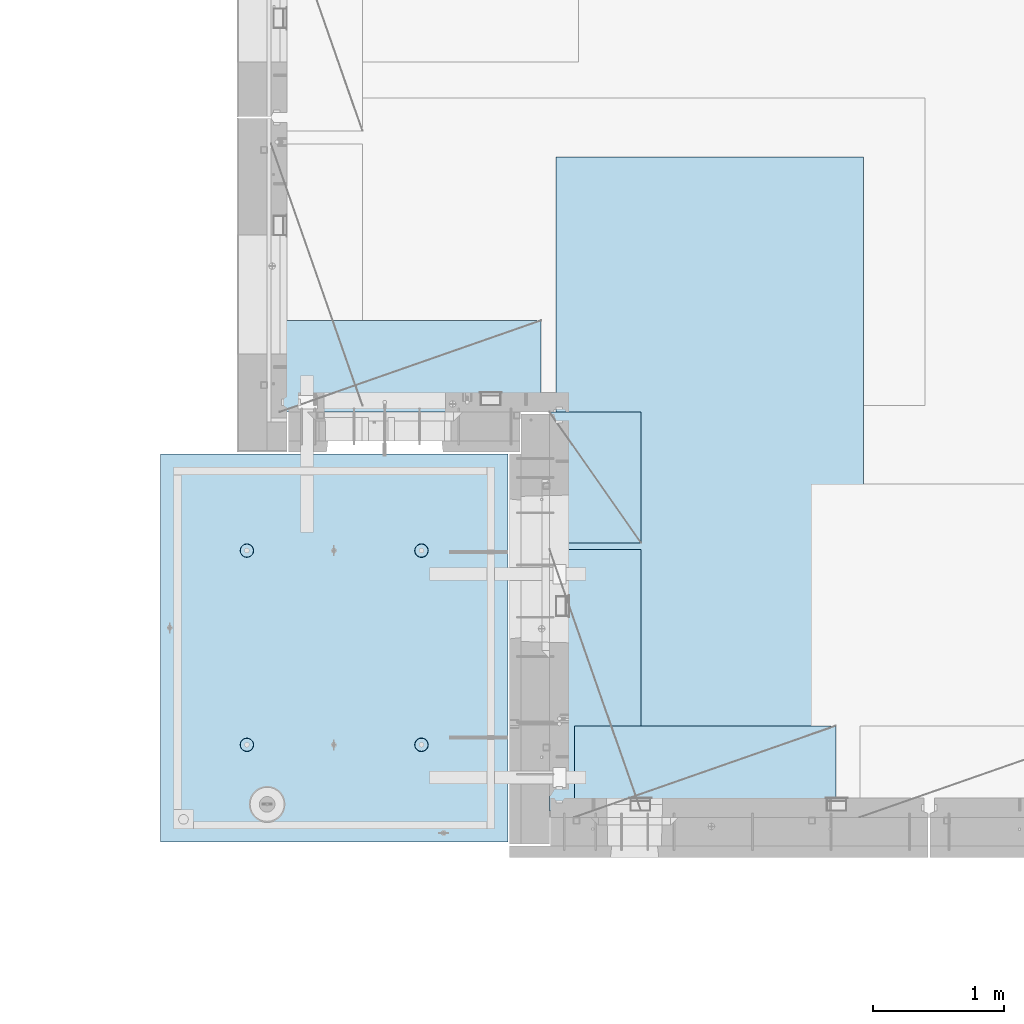
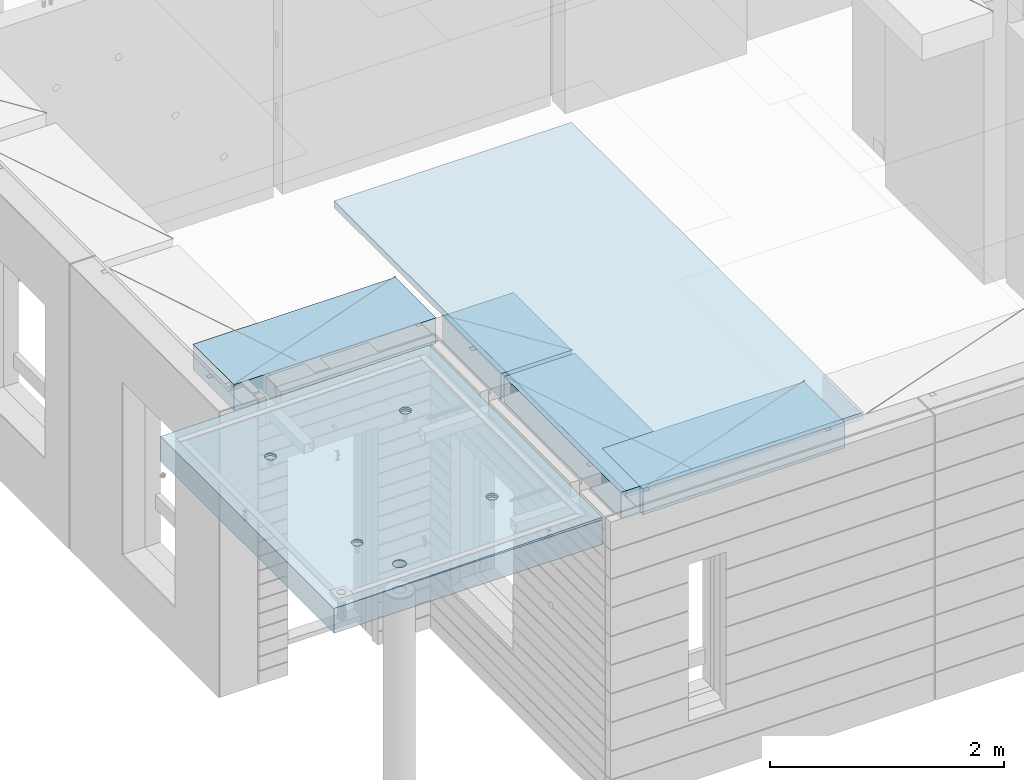
# One storey, part 198 of 352: 5 plates, 2 slabs, 6 elements without a shape of their own.
"""IFC2X3 building model written with IfcOpenShell, lengths in millimetres."""

from ifc_helpers import new_model, si_unit, frame, origin_with_axes, place, context, subcontext, project, spatial, faceted_brep, material, type_object, element, aggregate, save


model = new_model("IFC2X3")

# Units and contexts
model_context = context("Model", 3, precision=1e-05, world=origin_with_axes())
body_context = subcontext(model_context, "Body", "Model", "MODEL_VIEW")
ifc_project = project(units=[si_unit("LENGTHUNIT", "METRE", prefix="MILLI"), si_unit("AREAUNIT", "SQUARE_METRE"), si_unit("VOLUMEUNIT", "CUBIC_METRE"), si_unit("MASSUNIT", "GRAM", prefix="KILO"), si_unit("TIMEUNIT", "SECOND"), si_unit("PLANEANGLEUNIT", "RADIAN"), si_unit("SOLIDANGLEUNIT", "STERADIAN"), si_unit("THERMODYNAMICTEMPERATUREUNIT", "DEGREE_CELSIUS"), si_unit("LUMINOUSINTENSITYUNIT", "LUMEN")], contexts=[model_context])

# Site, building, storey
site_placement = place(None, origin_with_axes())
site = spatial("IfcSite", under=ifc_project, at=site_placement, CompositionType="ELEMENT")
building_placement = place(site_placement, origin_with_axes())
building = spatial("IfcBuilding", under=site, at=building_placement, CompositionType="ELEMENT")
storey_placement = place(building_placement, origin_with_axes())
storey = spatial("IfcBuildingStorey", under=building, at=storey_placement, Name="6", CompositionType="ELEMENT", Elevation=0.0)

# Assembly, slabs
assembly_1_placement = place(storey_placement, origin_with_axes())
assembly_1 = element("IfcElementAssembly", 1, at=assembly_1_placement, inside=storey, AssemblyPlace="NOTDEFINED", PredefinedType="REINFORCEMENT_UNIT")
ifc_material_1 = material(Name="CONCRETE/C35/45")
slab_type_1 = type_object("IfcSlabType", PredefinedType="NOTDEFINED")
slab_1_placement = place(assembly_1_placement, frame((9690.00344264774, 7659.99985681325, 99717.5), z_axis=(-1.0, 3.00000001838171e-08, 0.0), x_axis=(0.0, 1.0, 0.0)))
slab_1 = element("IfcSlab", 2, at=slab_1_placement, type_object=slab_type_1, material=ifc_material_1, PredefinedType="FLOOR", context=body_context, shape_type="Brep", body=[
    faceted_brep([(2970.0, 12.5, 2076.56396484375), (2970.0, 12.5, 2655.10375976563), (2970.0, 7.05330645262438, 2076.56396484375), (2970.0, 12.5, 0.0), (2969.99999999997, -12.5000027287315, -0.000215120240682154), (7.41420080885291e-08, 12.4999999999927, 0.0), (-7.41420080885291e-08, -12.5, -3.63797880709171e-12), (0.0, 12.5, 2655.00366210938), (2246.17288192116, -6.7539579669974, 610.235903379627), (2245.81872714612, 12.5, 611.325879700402), (2230.00000005311, 12.5, 608.820439463128), (2230.00000005311, -6.77809034052189, 607.672934085716), (2260.76019932669, -6.68392947182292, 617.673133503364), (2260.0890070157, 12.5, 618.596950465364), (2272.332530811, -6.57487936261168, 629.254531739907), (2271.41396524135, 12.5, 629.921908691014), (2279.75709784774, -6.43750647555862, 643.843854552742), (2278.68503600632, 12.5, 644.192188560603), (2282.30864751904, -6.2852774275234, 660.010915653605), (2281.19047624359, 12.5, 660.010915653605), (2279.73986529519, -6.13310092446045, 676.172377558725), (2278.68503600632, 12.5, 675.829642746608), (2272.30464795307, -5.995865551522, 690.747041485218), (2271.41396524135, 12.5, 690.099922616197), (2260.73231646608, -5.88698525390646, 702.310320338618), (2260.0890070157, 12.5, 701.424880841847), (2246.15564936427, -5.81709377811057, 709.732891570933), (2245.81872714612, 12.5, 708.695951606809), (2230.00000005311, -5.7930130083696, 712.290261666009), (2230.00000005311, 12.5, 711.201391844083), (2213.8443507625, -5.8170926610037, 709.732891507694), (2214.18127296011, 12.5, 708.695951606811), (2199.2676837145, -5.88698312871566, 702.310320236276), (2199.91099309052, 12.5, 701.424880841847), (2187.69535229405, -5.99586262571393, 690.747041382852), (2188.58603486487, 12.5, 690.099922616197), (2180.26013500581, -6.13309748387837, 676.172377495441), (2181.31496409991, 12.5, 675.829642746608), (2177.6913528026, -6.28527380865125, 660.010915653605), (2178.80952386264, 12.5, 660.010915653605), (2180.24290245339, -6.43750303260458, 643.843854616072), (2181.31496409991, 12.5, 644.192188560603), (2187.66746943631, -6.57487643294735, 629.254531842409), (2188.58603486487, 12.5, 629.921908691014), (2199.23980085403, -6.68392734277586, 617.673133605889), (2199.91099309052, 12.5, 618.596950465364), (2213.82711820565, -6.75395684751857, 610.235903443003), (2214.18127296011, 12.5, 611.325879700402), (761.172882674973, -6.75400078258826, 610.225900828256), (760.818727112381, 12.5, 611.315879572843), (745.000000019378, 12.5, 608.81043933557), (745.000000019378, -6.77813315729145, 607.662931409541), (775.760200790834, -6.68397228400863, 617.663131314152), (775.089006981969, 12.5, 618.586950337805), (787.33253283866, -6.57492216948594, 629.244530114656), (786.413965207619, 12.5, 629.911908563456), (794.757100236948, -6.437549275739, 643.833853637923), (793.685035972581, 12.5, 644.182188433044), (797.308650032492, -6.28532022031141, 660.000915526047), (796.190476209855, 12.5, 660.000915526047), (794.739867683551, -6.13314370981243, 676.162378218156), (793.685035972581, 12.5, 675.81964261905), (787.304649979378, -5.9959083302092, 690.737042854367), (786.413965207619, 12.5, 690.089922488638), (775.732317928869, -5.88702802728221, 702.300322270843), (775.089006981969, 12.5, 701.414880714288), (761.155650117242, -5.81713654809573, 709.722893864604), (760.818727112381, 12.5, 708.68595147925), (745.000000019378, -5.79305577717605, 712.280264084213), (745.000000019378, 12.5, 711.191391716524), (728.844349942063, -5.8171354309743, 709.722893801363), (729.181272926375, 12.5, 708.68595147925), (714.267682184241, -5.88702590207686, 702.300322168503), (714.910993056787, 12.5, 701.414880714288), (702.695350200273, -5.99590540440113, 690.737042752), (703.586034831136, 12.5, 690.089922488638), (695.260132549976, -6.1331402692449, 676.16237815487), (696.314964066174, 12.5, 675.81964261905), (692.691350221674, -6.28531660142471, 660.000915526047), (693.809523828902, 12.5, 660.000915526047), (695.242899996714, -6.43754583279951, 643.833853701251), (696.314964066174, 12.5, 644.182188433044), (702.667467341174, -6.57491923982161, 629.244530217156), (703.586034831136, 12.5, 629.911908563456), (714.239799322411, -6.68397015496157, 617.663131416677), (714.910993056787, 12.5, 618.586950337805), (728.827117384375, -6.75399966310943, 610.225900891632), (729.181272926375, 12.5, 611.315879572843), (760.941541335169, 5.82308796475991, 1945.93972725137), (760.818727091786, 12.5, 1946.31771062636), (744.999999998783, 12.5, 1943.81227038909), (744.999999998783, 5.79930078610778, 1943.4134192454), (775.320198478928, 5.89211475661432, 1953.2705735664), (775.089006961374, 12.5, 1953.58878139132), (786.72699673669, 5.99960498859582, 1964.68630888353), (786.413965187025, 12.5, 1964.91373961697), (794.045361100365, 6.13501286304381, 1979.06694274881), (793.685035951987, 12.5, 1979.18401948656), (796.560412832556, 6.28506439260673, 1995.00274657956), (796.190476189258, 12.5, 1995.00274657956), (794.028375046106, 6.43506412883289, 2010.93303130673), (793.685035951987, 12.5, 2010.82147367257), (786.699512721421, 6.57033645619231, 2025.29921596966), (786.413965187025, 12.5, 2025.09175354215), (775.292714461017, 6.67765930559835, 2036.69709108738), (775.089006961374, 12.5, 2036.41671176781), (760.924555276639, 6.74655103802797, 2044.01348819506), (760.818727091786, 12.5, 2043.68778253277), (744.999999998783, 6.7702873510425, 2046.53427709438), (744.999999998783, 12.5, 2046.19322277004), (729.075444741182, 6.7465521391714, 2044.01348813272), (729.18127290578, 12.5, 2043.68778253277), (714.70728560984, 6.67766140039021, 2036.6970909865), (714.910993036192, 12.5, 2036.41671176781), (703.300487415023, 6.57033934014908, 2025.29921586876), (703.586034810542, 12.5, 2025.09175354216), (695.971625143447, 6.43506752018584, 2010.93303124435), (696.314964045579, 12.5, 2010.82147367257), (693.439587377337, 6.28506795971771, 1995.00274657956), (693.809523808306, 12.5, 1995.00274657956), (695.954639089321, 6.13501625673962, 1979.06694281123), (696.314964045579, 12.5, 1979.18401948656), (703.273003399938, 5.99960787635064, 1964.68630898457), (703.586034810542, 12.5, 1964.91373961697), (714.679801592063, 5.89211685521877, 1953.27057366746), (714.910993036192, 12.5, 1953.58878139132), (729.058458682694, 5.82308906823164, 1945.93972731384), (729.18127290578, 12.5, 1946.31771062636), (2178.80952377932, 12.5, 1995.00274667064), (2178.43958429075, 6.28501659208268, 1995.00274667064), (2180.95463615188, 6.13496488021337, 1979.06694195729), (2181.31496401659, 12.5, 1979.18401957764), (2181.31496401659, 12.5, 2010.82147376364), (2180.97162220701, 6.43501616145659, 2010.93303228012), (2188.58603478155, 12.5, 2025.09175363323), (2188.3004849132, 6.57028798943793, 2025.29921775646), (2199.9109930072, 12.5, 2036.41671185888), (2199.70728378446, 6.6776100560528, 2036.6970935501), (2214.18127287679, 12.5, 2043.68778262385), (2214.07544376785, 6.74650079890853, 2044.0134911302), (2229.9999999698, 12.5, 2046.19322286112), (2229.9999999698, 6.77023601217661, 2046.53428024135), (2245.8187270628, 12.5, 2043.68778262385), (2245.924556192, 6.7464996977651, 2044.01349119253), (2260.08900693239, 12.5, 2036.41671185888), (2260.29271622843, 6.67760796126095, 2036.69709365098), (2271.41396515804, 12.5, 2025.09175363323), (2271.69951516527, 6.57028510548116, 2025.29921785736), (2278.685035923, 12.5, 2010.82147376364), (2279.02837792456, 6.43501277010364, 2010.9330323425), (2281.19047616027, 12.5, 1995.00274667064), (2281.56041586117, 6.2850130249717, 1995.00274667064), (2278.685035923, 12.5, 1979.18401957764), (2279.04536397983, 6.13496148651757, 1979.06694189487), (2271.41396515804, 12.5, 1964.91373970805), (2271.72699918216, 5.99955360403692, 1964.68630717681), (2260.08900693239, 12.5, 1953.5887814824), (2260.32020024797, 5.89206336568168, 1953.2705711827), (2245.8187270628, 12.5, 1946.31771071744), (2245.94154225154, 5.82303656973818, 1945.93972443295), (254.731823253564, 4.36849820162752, 1791.45731182264), (241.457918728614, 4.49348581883532, 1804.73121634759), (232.935547413403, 4.65097912067722, 1821.45731182264), (229.998938391112, 4.82556156541978, 1839.99833148514), (232.935547413403, 5.00014380698849, 1858.53935114764), (241.457918728614, 5.15763651921588, 1875.26544662269), (254.731823253564, 5.28262321809598, 1888.53935114764), (271.457918728614, 5.36286933471274, 1897.06172246285), (289.998938391112, 5.3905198200664, 1899.99833148514), (308.539958053609, 5.36286805199052, 1897.06172246285), (325.26605352866, 5.28262077822001, 1888.53935114764), (338.539958053609, 5.15763316099765, 1875.26544662269), (347.06232936882, 5.0001398591703, 1858.53935114764), (349.998938391112, 4.82555741442775, 1839.99833148514), (347.06232936882, 4.65097517284448, 1821.45731182264), (338.539958053609, 4.49348246061709, 1804.73121634759), (325.26605352866, 4.36849576173699, 1791.45731182264), (308.539958053609, 4.28824964510568, 1782.93494050743), (289.998938391112, 4.26059915976657, 1779.99833148514), (271.457918728614, 4.28825092784246, 1782.93494050743), (2199.67979976505, 5.89206546428613, 1953.27057128376), (2188.27300089649, 5.99955649179174, 1964.68630727784), (2229.9999999698, 5.79924938967451, 1943.41341627717), (2214.05845770835, 5.82303767320991, 1945.93972449542), (2188.58603478155, 12.5, 1964.91373970805), (2199.9109930072, 12.5, 1953.5887814824), (2214.18127287679, 12.5, 1946.31771071744), (2229.9999999698, 12.5, 1943.81227048017), (325.26605352866, 12.5, 1791.45731182264), (338.539958053609, 12.5, 1804.73121634759), (347.06232936882, 12.5, 1821.45731182264), (349.998938391112, 12.5, 1839.99833148514), (347.06232936882, 12.5, 1858.53935114764), (338.539958053609, 12.5, 1875.26544662269), (325.26605352866, 12.5, 1888.53935114764), (308.539958053609, 12.5, 1897.06172246285), (289.998938391112, 12.5, 1899.99833148514), (271.457918728614, 12.5, 1897.06172246285), (254.731823253564, 12.5, 1888.53935114764), (241.457918728614, 12.5, 1875.26544662269), (232.935547413403, 12.5, 1858.53935114764), (229.998938391112, 12.5, 1839.99833148514), (232.935547413403, 12.5, 1821.45731182264), (241.457918728614, 12.5, 1804.73121634759), (254.731823253564, 12.5, 1791.45731182264), (271.457918728614, 12.5, 1782.93494050743), (289.998938391112, 12.5, 1779.99833148514), (308.539958053609, 12.5, 1782.93494050743)], [[[0, 1, 2]], [[3, 0, 2, 4]], [[5, 3, 4, 6]], [[5, 6, 7]], [[8, 9, 10, 11]], [[12, 13, 9, 8]], [[14, 15, 13, 12]], [[16, 17, 15, 14]], [[18, 19, 17, 16]], [[20, 21, 19, 18]], [[21, 20, 22, 23]], [[23, 22, 24, 25]], [[25, 24, 26, 27]], [[27, 26, 28, 29]], [[29, 28, 30, 31]], [[31, 30, 32, 33]], [[33, 32, 34, 35]], [[35, 34, 36, 37]], [[37, 36, 38, 39]], [[40, 41, 39, 38]], [[42, 43, 41, 40]], [[44, 45, 43, 42]], [[46, 47, 45, 44]], [[11, 10, 47, 46]], [[48, 49, 50, 51]], [[52, 53, 49, 48]], [[54, 55, 53, 52]], [[56, 57, 55, 54]], [[58, 59, 57, 56]], [[60, 61, 59, 58]], [[61, 60, 62, 63]], [[63, 62, 64, 65]], [[65, 64, 66, 67]], [[67, 66, 68, 69]], [[69, 68, 70, 71]], [[71, 70, 72, 73]], [[73, 72, 74, 75]], [[75, 74, 76, 77]], [[77, 76, 78, 79]], [[80, 81, 79, 78]], [[82, 83, 81, 80]], [[84, 85, 83, 82]], [[86, 87, 85, 84]], [[51, 50, 87, 86]], [[88, 89, 90, 91]], [[92, 93, 89, 88]], [[94, 95, 93, 92]], [[96, 97, 95, 94]], [[98, 99, 97, 96]], [[100, 101, 99, 98]], [[102, 103, 101, 100]], [[104, 105, 103, 102]], [[105, 104, 106, 107]], [[107, 106, 108, 109]], [[109, 108, 110, 111]], [[111, 110, 112, 113]], [[113, 112, 114, 115]], [[115, 114, 116, 117]], [[117, 116, 118, 119]], [[119, 118, 120, 121]], [[121, 120, 122, 123]], [[124, 125, 123, 122]], [[126, 127, 125, 124]], [[91, 90, 127, 126]], [[128, 129, 130, 131]], [[132, 133, 129, 128]], [[134, 135, 133, 132]], [[136, 137, 135, 134]], [[138, 139, 137, 136]], [[140, 141, 139, 138]], [[142, 143, 141, 140]], [[144, 145, 143, 142]], [[145, 144, 146, 147]], [[147, 146, 148, 149]], [[149, 148, 150, 151]], [[151, 150, 152, 153]], [[153, 152, 154, 155]], [[155, 154, 156, 157]], [[157, 156, 158, 159]], [[4, 2, 1, 7, 6], [160, 161, 162, 163, 164, 165, 166, 167, 168, 169, 170, 171, 172, 173, 174, 175, 176, 177, 178, 179], [180, 181, 130, 129, 133, 135, 137, 139, 141, 143, 145, 147, 149, 151, 153, 155, 157, 159, 182, 183], [124, 122, 120, 118, 116, 114, 112, 110, 108, 106, 104, 102, 100, 98, 96, 94, 92, 88, 91, 126], [84, 82, 80, 78, 76, 74, 72, 70, 68, 66, 64, 62, 60, 58, 56, 54, 52, 48, 51, 86], [44, 42, 40, 38, 36, 34, 32, 30, 28, 26, 24, 22, 20, 18, 16, 14, 12, 8, 11, 46]], [[131, 130, 181, 184]], [[180, 185, 184, 181]], [[183, 186, 185, 180]], [[182, 187, 186, 183]], [[159, 158, 187, 182]], [[0, 3, 5, 7, 1], [188, 189, 190, 191, 192, 193, 194, 195, 196, 197, 198, 199, 200, 201, 202, 203, 204, 205, 206, 207], [156, 154, 152, 150, 148, 146, 144, 142, 140, 138, 136, 134, 132, 128, 131, 184, 185, 186, 187, 158], [93, 95, 97, 99, 101, 103, 105, 107, 109, 111, 113, 115, 117, 119, 121, 123, 125, 127, 90, 89], [53, 55, 57, 59, 61, 63, 65, 67, 69, 71, 73, 75, 77, 79, 81, 83, 85, 87, 50, 49], [13, 15, 17, 19, 21, 23, 25, 27, 29, 31, 33, 35, 37, 39, 41, 43, 45, 47, 10, 9]], [[178, 206, 205, 179]], [[177, 207, 206, 178]], [[176, 188, 207, 177]], [[175, 189, 188, 176]], [[174, 190, 189, 175]], [[173, 191, 190, 174]], [[172, 192, 191, 173]], [[171, 193, 192, 172]], [[170, 194, 193, 171]], [[169, 195, 194, 170]], [[168, 196, 195, 169]], [[167, 197, 196, 168]], [[166, 198, 197, 167]], [[165, 199, 198, 166]], [[164, 200, 199, 165]], [[163, 201, 200, 164]], [[162, 202, 201, 163]], [[161, 203, 202, 162]], [[160, 204, 203, 161]], [[179, 205, 204, 160]]]),
])
slab_type_2 = type_object("IfcSlabType", PredefinedType="NOTDEFINED")
slab_2_placement = place(assembly_1_placement, frame((9690.00344264774, 7659.99985681325, 99575.0), z_axis=(-0.999999999997437, -2.26400000064461e-06, 0.0), x_axis=(-2.2639999995273e-06, 0.999999999997437, 0.0)))
slab_2 = element("IfcSlab", 3, at=slab_2_placement, type_object=slab_type_2, material=ifc_material_1, PredefinedType="FLOOR", context=body_context, shape_type="Brep", body=[
    faceted_brep([(2245.45536387143, -110.0, 1947.44471589559), (2259.39379322965, -110.0, 1954.54665968234), (2270.4554059745, -110.0, 1965.60822114567), (2277.55741437973, -110.0, 1979.54661757913), (2280.00462438004, -110.0, 1994.99746162528), (2277.55748600988, -110.0, 2010.44831701654), (2270.45554222312, -110.0, 2024.38674637476), (2259.39398075979, -110.0, 2035.44835911961), (2245.45558432633, -110.0, 2042.55036752485), (2230.00474028018, -110.0, 2044.99757752515), (2214.55388488892, -110.0, 2042.55043915498), (2200.6154555307, -110.0, 2035.44849536823), (2189.55384278585, -110.0, 2024.3869339049), (2182.45183438062, -110.0, 2010.44853747144), (2180.00462438031, -110.0, 1994.99769342529), (2182.45176275048, -110.0, 1979.54683803403), (2189.55370653723, -110.0, 1965.60840867581), (2200.61526800056, -110.0, 1954.54679593096), (2214.55366443402, -110.0, 1947.44478752572), (2230.00450848018, -110.0, 1944.99757752542), (2260.09353534512, -130.0, 1953.58354259084), (2245.82323862122, -130.0, 1946.3125049044), (2271.41851982199, -130.0, 1964.9084745652), (2278.68962366544, -130.0, 1979.17873758041), (2281.19510057052, -130.0, 1994.99745886576), (2278.68969700106, -130.0, 2010.81619176633), (2271.41865931462, -130.0, 2025.08648849022), (2260.09372734026, -130.0, 2036.4114729671), (2245.82346432505, -130.0, 2043.68257681055), (2230.0047430397, -130.0, 2046.18805371562), (2214.18601013913, -130.0, 2043.68265014617), (2199.91571341524, -130.0, 2036.41161245973), (2188.59072893836, -130.0, 2025.08668048537), (2181.31962509491, -130.0, 2010.81641747016), (2178.81414818984, -130.0, 1994.99769618481), (2181.31955175929, -130.0, 1979.17896328424), (2188.59058944573, -130.0, 1964.90866656035), (2199.91552142009, -130.0, 1953.58368208347), (2214.1857844353, -130.0, 1946.31257824002), (2230.00450572065, -130.0, 1943.80710133495), (760.455363904408, -110.0, 1947.44815803451), (774.393793262629, -110.0, 1954.55010182126), (785.455406007481, -110.0, 1965.61166328459), (792.557414412711, -110.0, 1979.55005971805), (795.004624413019, -110.0, 1995.00090376421), (792.557486042851, -110.0, 2010.45175915546), (785.455542256102, -110.0, 2024.39018851368), (774.393980792767, -110.0, 2035.45180125853), (760.455584359308, -110.0, 2042.55380966377), (745.004740313152, -110.0, 2045.00101966407), (729.553884921896, -110.0, 2042.55388129391), (715.615455563677, -110.0, 2035.45193750716), (704.553842818825, -110.0, 2024.39037604382), (697.451834413594, -110.0, 2010.45197961036), (695.004624413286, -110.0, 1995.00113556421), (697.451762783454, -110.0, 1979.55028017295), (704.553706570203, -110.0, 1965.61185081473), (715.615268033538, -110.0, 1954.55023806988), (729.553664466996, -110.0, 1947.44822966465), (745.004508513151, -110.0, 1945.00101966434), (760.823238654199, -130.0, 1946.31594704332), (745.004505753628, -130.0, 1943.81054347387), (775.093535378091, -130.0, 1953.58698472976), (786.418519854964, -130.0, 1964.91191670413), (793.689623698416, -130.0, 1979.18217971933), (796.195100603492, -130.0, 1995.00090100468), (793.689697034035, -130.0, 2010.81963390525), (786.418659347601, -130.0, 2025.08993062915), (775.093727373234, -130.0, 2036.41491510602), (760.823464358025, -130.0, 2043.68601894947), (745.004743072675, -130.0, 2046.19149585455), (729.186010172105, -130.0, 2043.68609228509), (714.915713448214, -130.0, 2036.41505459866), (703.590728971341, -130.0, 2025.09012262429), (696.319625127888, -130.0, 2010.81985960908), (693.814148222813, -130.0, 1995.00113832373), (696.319551792269, -130.0, 1979.18240542316), (703.590589478705, -130.0, 1964.91210869927), (714.915521453071, -130.0, 1953.5871242224), (729.185784468278, -130.0, 1946.31602037894), (2970.0, -130.0, 1.11504050437361e-09), (0.0, -130.0, -3.63797880709171e-12), (0.0, 130.0, -1.81898940354586e-12), (2970.0, 130.0, 1.11504050437361e-09), (2970.0048828125, -130.0, 2076.55712890625), (2970.0048828125, 130.0, 2076.55712890625), (2970.00610351563, -130.0, 2655.0966796875), (2970.00610351563, 130.0, 2655.0966796875), (0.00277573079893045, -130.0, 2655.00366210937), (0.00277573079893045, 130.0, 2655.00366210937), (325.270206125839, 130.0, 1791.45655785112), (338.544141419662, 130.0, 1804.73043160713), (347.066551505941, 130.0, 1821.45650732727), (350.003203506308, 130.0, 1839.99752018266), (347.066637462108, 130.0, 1858.53854665217), (338.544304918008, 130.0, 1875.26466188203), (325.270431162006, 130.0, 1888.53859717586), (308.544355441856, 130.0, 1897.06100726213), (290.003342586469, 130.0, 1899.9976592625), (271.462316116962, 130.0, 1897.0610932183), (254.7362008871, 130.0, 1888.5387606742), (241.462265593274, 130.0, 1875.2648869182), (232.939855506997, 130.0, 1858.53881119805), (230.00320350663, 130.0, 1839.99779834266), (232.93976955083, 130.0, 1821.45677187316), (241.462102094929, 130.0, 1804.73065664329), (254.735975850932, 130.0, 1791.45672134947), (271.462051571081, 130.0, 1782.93431126319), (290.003064426469, 130.0, 1779.99765926282), (308.544090895975, 130.0, 1782.93422530702), (308.544090895975, -130.0, 1782.93422530702), (290.003064426469, -130.0, 1779.99765926282), (325.270206125839, -130.0, 1791.45655785112), (338.544141419662, -130.0, 1804.73043160713), (347.066551505941, -130.0, 1821.45650732727), (350.003203506308, -130.0, 1839.99752018266), (347.066637462108, -130.0, 1858.53854665217), (338.544304918008, -130.0, 1875.26466188203), (325.270431162006, -130.0, 1888.53859717586), (308.544355441856, -130.0, 1897.06100726213), (290.003342586469, -130.0, 1899.9976592625), (271.462316116962, -130.0, 1897.0610932183), (254.7362008871, -130.0, 1888.5387606742), (241.462265593274, -130.0, 1875.2648869182), (232.939855506997, -130.0, 1858.53881119805), (230.00320350663, -130.0, 1839.99779834266), (232.93976955083, -130.0, 1821.45677187316), (241.462102094929, -130.0, 1804.73065664329), (254.735975850932, -130.0, 1791.45672134947), (271.462051571081, -130.0, 1782.93431126319), (760.452269390758, -110.0, 612.446326984578), (774.390698748979, -110.0, 619.548270771327), (785.452311493831, -110.0, 630.609832234661), (792.554319899062, -110.0, 644.54822866812), (795.001529899369, -110.0, 659.999072714278), (792.554391529202, -110.0, 675.449928105532), (785.452447742453, -110.0, 689.388357463751), (774.390886279118, -110.0, 700.449970208605), (760.452489845658, -110.0, 707.551978613836), (745.001645799503, -110.0, 709.999188614142), (729.550790408246, -110.0, 707.552050243974), (715.612361050027, -110.0, 700.450106457225), (704.550748305175, -110.0, 689.388544993892), (697.448739899944, -110.0, 675.450148560432), (695.001529899637, -110.0, 659.999304514276), (697.448668269804, -110.0, 644.54844912302), (704.550612056553, -110.0, 630.610019764801), (715.612173519889, -110.0, 619.548407019947), (729.550569953346, -110.0, 612.446398614717), (745.001413999502, -110.0, 609.999188614411), (760.820144140549, -130.0, 611.314115993395), (745.001411239979, -130.0, 608.808712423936), (775.090440864442, -130.0, 618.585153679829), (786.415425341314, -130.0, 629.910085654195), (793.686529184766, -130.0, 644.180348669403), (796.192006089843, -130.0, 659.999069954752), (793.686602520385, -130.0, 675.817802855323), (786.415564833951, -130.0, 690.088099579216), (775.090632859585, -130.0, 701.41308405609), (760.820369844376, -130.0, 708.68418789954), (745.001648559026, -130.0, 711.189664804615), (729.182915658455, -130.0, 708.684261235159), (714.912618934564, -130.0, 701.413223548725), (703.587634457692, -130.0, 690.088291574357), (696.316530614238, -130.0, 675.81802855915), (693.811053709163, -130.0, 659.999307273802), (696.316457278619, -130.0, 644.180574373229), (703.587494965055, -130.0, 629.910277649336), (714.912426939421, -130.0, 618.585293172464), (729.182689954629, -130.0, 611.314189329014), (2245.45226944368, -110.0, 612.452884882137), (2259.3906988019, -110.0, 619.554828668886), (2270.45231154675, -110.0, 630.61639013222), (2277.55431995199, -110.0, 644.554786565679), (2280.00152995229, -110.0, 660.005630611837), (2277.55439158212, -110.0, 675.456486003091), (2270.45244779537, -110.0, 689.39491536131), (2259.39088633204, -110.0, 700.456528106164), (2245.45248989858, -110.0, 707.558536511395), (2230.00164585242, -110.0, 710.005746511701), (2214.55079046117, -110.0, 707.558608141533), (2200.61236110295, -110.0, 700.456664354784), (2189.5507483581, -110.0, 689.395102891451), (2182.44873995286, -110.0, 675.456706457991), (2180.00152995256, -110.0, 660.005862411836), (2182.44866832273, -110.0, 644.555007020579), (2189.55061210948, -110.0, 630.61657766236), (2200.61217357281, -110.0, 619.554964917506), (2214.55057000627, -110.0, 612.452956512276), (2230.00141405243, -110.0, 610.00574651197), (2245.82014419347, -130.0, 611.320673890954), (2230.0014112929, -130.0, 608.815270321495), (2260.09044091736, -130.0, 618.591711577388), (2271.41542539424, -130.0, 629.916643551753), (2278.68652923769, -130.0, 644.186906566962), (2281.19200614276, -130.0, 660.005627852312), (2278.68660257331, -130.0, 675.824360752882), (2271.41556488687, -130.0, 690.094657476773), (2260.09063291251, -130.0, 701.419641953647), (2245.8203698973, -130.0, 708.690745797099), (2230.00164861195, -130.0, 711.196222702174), (2214.18291571138, -130.0, 708.690819132718), (2199.91261898749, -130.0, 701.419781446282), (2188.58763451061, -130.0, 690.094849471916), (2181.31653066716, -130.0, 675.824586456709), (2178.81105376209, -130.0, 660.005865171361), (2181.31645733154, -130.0, 644.187132270788), (2188.58749501798, -130.0, 629.916835546896), (2199.91242699234, -130.0, 618.591851070023), (2214.18269000755, -130.0, 611.320747226573)], [[[0, 1, 2, 3, 4, 5, 6, 7, 8, 9, 10, 11, 12, 13, 14, 15, 16, 17, 18, 19]], [[20, 1, 0, 21]], [[22, 2, 1, 20]], [[23, 3, 2, 22]], [[24, 4, 3, 23]], [[25, 5, 4, 24]], [[26, 6, 5, 25]], [[27, 7, 6, 26]], [[28, 8, 7, 27]], [[29, 9, 8, 28]], [[30, 10, 9, 29]], [[31, 11, 10, 30]], [[32, 12, 11, 31]], [[33, 13, 12, 32]], [[34, 14, 13, 33]], [[35, 15, 14, 34]], [[36, 16, 15, 35]], [[37, 17, 16, 36]], [[38, 18, 17, 37]], [[39, 19, 18, 38]], [[21, 0, 19, 39]], [[40, 41, 42, 43, 44, 45, 46, 47, 48, 49, 50, 51, 52, 53, 54, 55, 56, 57, 58, 59]], [[60, 40, 59, 61]], [[62, 41, 40, 60]], [[63, 42, 41, 62]], [[64, 43, 42, 63]], [[65, 44, 43, 64]], [[66, 45, 44, 65]], [[67, 46, 45, 66]], [[68, 47, 46, 67]], [[69, 48, 47, 68]], [[70, 49, 48, 69]], [[71, 50, 49, 70]], [[72, 51, 50, 71]], [[73, 52, 51, 72]], [[74, 53, 52, 73]], [[75, 54, 53, 74]], [[76, 55, 54, 75]], [[77, 56, 55, 76]], [[78, 57, 56, 77]], [[79, 58, 57, 78]], [[61, 59, 58, 79]], [[80, 81, 82, 83]], [[84, 80, 83, 85]], [[86, 84, 85, 87]], [[88, 86, 87, 89]], [[81, 88, 89, 82]], [[87, 85, 83, 82, 89], [90, 91, 92, 93, 94, 95, 96, 97, 98, 99, 100, 101, 102, 103, 104, 105, 106, 107, 108, 109]], [[110, 109, 108, 111]], [[112, 90, 109, 110]], [[113, 91, 90, 112]], [[114, 92, 91, 113]], [[115, 93, 92, 114]], [[116, 94, 93, 115]], [[117, 95, 94, 116]], [[118, 96, 95, 117]], [[119, 97, 96, 118]], [[120, 98, 97, 119]], [[121, 99, 98, 120]], [[122, 100, 99, 121]], [[123, 101, 100, 122]], [[124, 102, 101, 123]], [[125, 103, 102, 124]], [[126, 104, 103, 125]], [[127, 105, 104, 126]], [[128, 106, 105, 127]], [[129, 107, 106, 128]], [[111, 108, 107, 129]], [[130, 131, 132, 133, 134, 135, 136, 137, 138, 139, 140, 141, 142, 143, 144, 145, 146, 147, 148, 149]], [[150, 130, 149, 151]], [[152, 131, 130, 150]], [[153, 132, 131, 152]], [[154, 133, 132, 153]], [[155, 134, 133, 154]], [[156, 135, 134, 155]], [[157, 136, 135, 156]], [[158, 137, 136, 157]], [[159, 138, 137, 158]], [[160, 139, 138, 159]], [[161, 140, 139, 160]], [[162, 141, 140, 161]], [[163, 142, 141, 162]], [[164, 143, 142, 163]], [[165, 144, 143, 164]], [[166, 145, 144, 165]], [[167, 146, 145, 166]], [[168, 147, 146, 167]], [[169, 148, 147, 168]], [[151, 149, 148, 169]], [[170, 171, 172, 173, 174, 175, 176, 177, 178, 179, 180, 181, 182, 183, 184, 185, 186, 187, 188, 189]], [[190, 170, 189, 191]], [[192, 171, 170, 190]], [[193, 172, 171, 192]], [[194, 173, 172, 193]], [[195, 174, 173, 194]], [[196, 175, 174, 195]], [[197, 176, 175, 196]], [[198, 177, 176, 197]], [[199, 178, 177, 198]], [[200, 179, 178, 199]], [[201, 180, 179, 200]], [[202, 181, 180, 201]], [[203, 182, 181, 202]], [[204, 183, 182, 203]], [[205, 184, 183, 204]], [[206, 185, 184, 205]], [[207, 186, 185, 206]], [[208, 187, 186, 207]], [[209, 188, 187, 208]], [[191, 189, 188, 209]], [[80, 84, 86, 88, 81], [37, 36, 35, 34, 33, 32, 31, 30, 29, 28, 27, 26, 25, 24, 23, 22, 20, 21, 39, 38], [208, 207, 206, 205, 204, 203, 202, 201, 200, 199, 198, 197, 196, 195, 194, 193, 192, 190, 191, 209], [168, 167, 166, 165, 164, 163, 162, 161, 160, 159, 158, 157, 156, 155, 154, 153, 152, 150, 151, 169], [128, 127, 126, 125, 124, 123, 122, 121, 120, 119, 118, 117, 116, 115, 114, 113, 112, 110, 111, 129], [78, 77, 76, 75, 74, 73, 72, 71, 70, 69, 68, 67, 66, 65, 64, 63, 62, 60, 61, 79]]]),
])
aggregate(assembly_1, [slab_1, slab_2])

# Assembly, plate
assembly_2_placement = place(storey_placement, origin_with_axes())
assembly_2 = element("IfcElementAssembly", 4, at=assembly_2_placement, inside=storey, Name="Steel Assembly", AssemblyPlace="NOTDEFINED", PredefinedType="NOTDEFINED")
ifc_material_2 = material()
plate_type_1 = type_object("IfcPlateType", PredefinedType="NOTDEFINED")
plate_1_placement = place(assembly_2_placement, frame((10060.0, 7900.0, 99695.1), z_axis=(0.0, 1.0, 0.0), x_axis=(1.0, 0.0, 0.0)))
plate_1 = element("IfcPlate", 5, at=plate_1_placement, type_object=plate_type_1, material=ifc_material_2, context=body_context, shape_type="Brep", body=[
    faceted_brep([(0.0, -35.0, 0.0), (0.0, -35.0, 5000.0), (0.0, 35.0, 5000.0), (0.0, 35.0, 0.0), (2349.99951171875, -35.0, 5000.0), (2349.99951171875, 35.0, 5000.0), (2350.0, -35.0, 0.0), (2350.0, 35.0, 0.0)], [[[0, 1, 2, 3]], [[1, 4, 5, 2]], [[4, 6, 7, 5]], [[6, 0, 3, 7]], [[5, 7, 3, 2]], [[6, 4, 1, 0]]]),
])
aggregate(assembly_2, [plate_1])

assembly_3_placement = place(storey_placement, origin_with_axes())
assembly_3 = element("IfcElementAssembly", 6, at=assembly_3_placement, inside=storey, Name="Steel Assembly", AssemblyPlace="NOTDEFINED", PredefinedType="NOTDEFINED")
plate_type_2 = type_object("IfcPlateType", PredefinedType="NOTDEFINED")
plate_2_placement = place(assembly_3_placement, frame((7945.00085423865, 10950.0001036336, 99595.3), z_axis=(0.0, 1.0, 0.0), x_axis=(1.0, 0.0, 0.0)))
plate_2 = element("IfcPlate", 7, at=plate_2_placement, type_object=plate_type_2, material=ifc_material_2, Name="RE1", context=body_context, shape_type="Brep", body=[
    faceted_brep([(1.81898940354586e-12, -135.0, 1.81898940354586e-12), (0.0, -135.0, 699.999999999996), (0.0, 135.0, 699.999999999996), (1.81898940354586e-12, 135.0, 1.81898940354586e-12), (1999.99951171875, -135.0, 699.999999999993), (1999.99951171875, 135.0, 699.999999999993), (2000.0, -135.0, -3.63797880709171e-12), (2000.0, 135.0, -3.63797880709171e-12)], [[[0, 1, 2, 3]], [[1, 4, 5, 2]], [[4, 6, 7, 5]], [[6, 0, 3, 7]], [[5, 7, 3, 2]], [[6, 4, 1, 0]]]),
])
aggregate(assembly_3, [plate_2])

assembly_4_placement = place(storey_placement, origin_with_axes())
assembly_4 = element("IfcElementAssembly", 8, at=assembly_4_placement, inside=storey, Name="Steel Assembly", AssemblyPlace="NOTDEFINED", PredefinedType="NOTDEFINED")
plate_3_placement = place(assembly_4_placement, frame((10009.9998779297, 9900.0, 99595.3), z_axis=(1.0, 0.0, 0.0), x_axis=(0.0, -1.0, 0.0)))
plate_3 = element("IfcPlate", 9, at=plate_3_placement, type_object=plate_type_2, material=ifc_material_2, Name="RE1", context=body_context, shape_type="Brep", body=[
    faceted_brep([(1.81898940354586e-12, -135.0, 1.81898940354586e-12), (0.0, -135.0, 699.999999999996), (0.0, 135.0, 699.999999999996), (1.81898940354586e-12, 135.0, 1.81898940354586e-12), (1999.99951171875, -135.0, 699.999999999993), (1999.99951171875, 135.0, 699.999999999993), (2000.0, -135.0, -3.63797880709171e-12), (2000.0, 135.0, -3.63797880709171e-12)], [[[0, 1, 2, 3]], [[1, 4, 5, 2]], [[4, 6, 7, 5]], [[6, 0, 3, 7]], [[5, 7, 3, 2]], [[6, 4, 1, 0]]]),
])
aggregate(assembly_4, [plate_3])

assembly_5_placement = place(storey_placement, origin_with_axes())
assembly_5 = element("IfcElementAssembly", 10, at=assembly_5_placement, inside=storey, Name="Steel Assembly", AssemblyPlace="NOTDEFINED", PredefinedType="NOTDEFINED")
plate_4_placement = place(assembly_5_placement, frame((10009.9999999293, 10950.0, 99595.3), z_axis=(1.0, 0.0, 0.0), x_axis=(0.0, -1.0, 0.0)))
plate_4 = element("IfcPlate", 11, at=plate_4_placement, type_object=plate_type_2, material=ifc_material_2, Name="RE1_1/2", context=body_context, shape_type="Brep", body=[
    faceted_brep([(1.81898940354586e-12, -135.0, 1.81898940354586e-12), (0.0, -135.0, 699.999999999996), (0.0, 135.0, 699.999999999996), (1.81898940354586e-12, 135.0, 1.81898940354586e-12), (999.99951171875, -135.0, 700.0), (999.99951171875, 135.0, 700.0), (1000.0, -135.0, 0.0), (1000.0, 135.0, 0.0)], [[[0, 1, 2, 3]], [[1, 4, 5, 2]], [[4, 6, 7, 5]], [[6, 0, 3, 7]], [[5, 7, 3, 2]], [[6, 4, 1, 0]]]),
])
aggregate(assembly_5, [plate_4])

assembly_6_placement = place(storey_placement, origin_with_axes())
assembly_6 = element("IfcElementAssembly", 12, at=assembly_6_placement, inside=storey, Name="Steel Assembly", AssemblyPlace="NOTDEFINED", PredefinedType="NOTDEFINED")
plate_5_placement = place(assembly_6_placement, frame((10200.0008542386, 7850.00010363356, 99595.3), z_axis=(0.0, 1.0, 0.0), x_axis=(1.0, 0.0, 0.0)))
plate_5 = element("IfcPlate", 13, at=plate_5_placement, type_object=plate_type_2, material=ifc_material_2, Name="RE1", context=body_context, shape_type="Brep", body=[
    faceted_brep([(1.81898940354586e-12, -135.0, 1.81898940354586e-12), (0.0, -135.0, 699.999999999996), (0.0, 135.0, 699.999999999996), (1.81898940354586e-12, 135.0, 1.81898940354586e-12), (1999.99951171875, -135.0, 699.999999999993), (1999.99951171875, 135.0, 699.999999999993), (2000.0, -135.0, -3.63797880709171e-12), (2000.0, 135.0, -3.63797880709171e-12)], [[[0, 1, 2, 3]], [[1, 4, 5, 2]], [[4, 6, 7, 5]], [[6, 0, 3, 7]], [[5, 7, 3, 2]], [[6, 4, 1, 0]]]),
])
aggregate(assembly_6, [plate_5])

save(model, "model.ifc")
